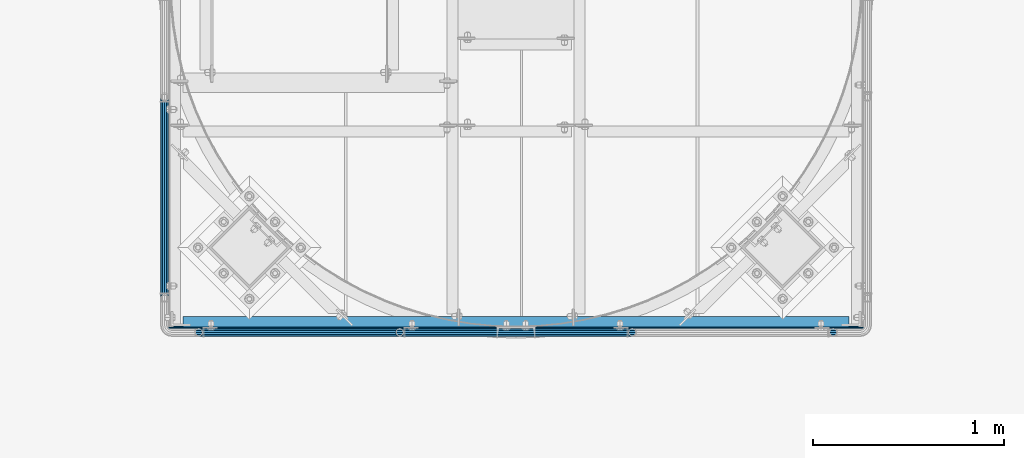
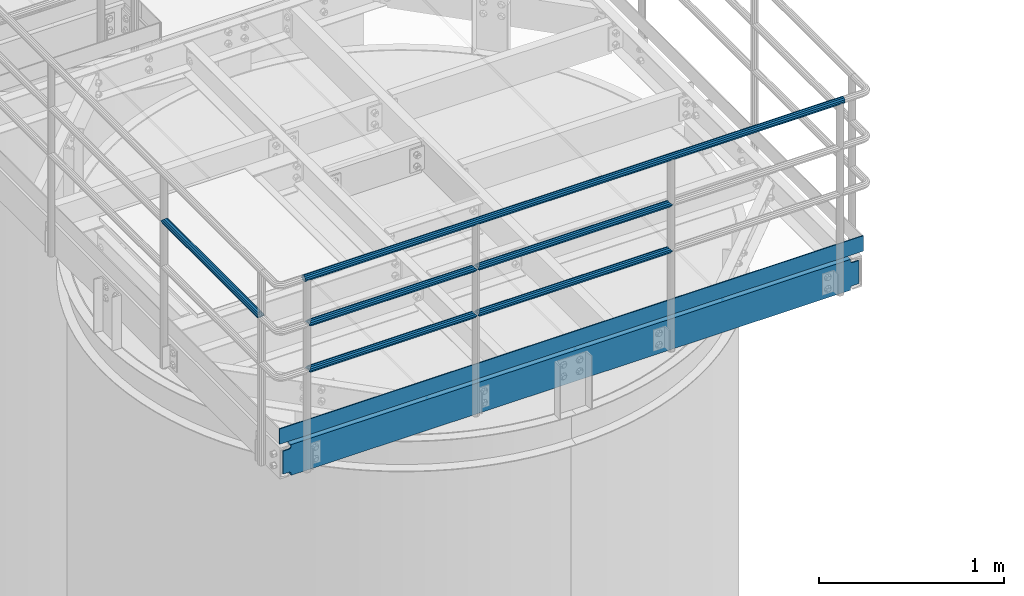
# One storey, part 914 of 1876: 8 beams, 3 elements without a shape of their own.
"""IFC2X3 building model written with IfcOpenShell, lengths in millimetres."""

from ifc_helpers import new_model, si_unit, frame, origin_with_axes, place, context, subcontext, project, spatial, faceted_brep, material, type_object, element, aggregate, save


model = new_model("IFC2X3")

# Units and contexts
model_context = context("Model", 3, precision=1e-05, world=origin_with_axes())
body_context = subcontext(model_context, "Body", "Model", "MODEL_VIEW")
ifc_project = project(units=[si_unit("LENGTHUNIT", "METRE", prefix="MILLI"), si_unit("AREAUNIT", "SQUARE_METRE"), si_unit("VOLUMEUNIT", "CUBIC_METRE"), si_unit("MASSUNIT", "GRAM", prefix="KILO"), si_unit("TIMEUNIT", "SECOND"), si_unit("PLANEANGLEUNIT", "RADIAN"), si_unit("SOLIDANGLEUNIT", "STERADIAN"), si_unit("THERMODYNAMICTEMPERATUREUNIT", "DEGREE_CELSIUS"), si_unit("LUMINOUSINTENSITYUNIT", "LUMEN")], contexts=[model_context])

# Site, building, storey
site_placement = place(None, origin_with_axes())
site = spatial("IfcSite", under=ifc_project, at=site_placement, CompositionType="ELEMENT")
building_placement = place(site_placement, origin_with_axes())
building = spatial("IfcBuilding", under=site, at=building_placement, Name="Undefined", CompositionType="ELEMENT")
storey_placement = place(building_placement, origin_with_axes())
storey = spatial("IfcBuildingStorey", under=building, at=storey_placement, Name="Undefined", CompositionType="ELEMENT", Elevation=0.0)

# Assembly, beams
assembly_1_placement = place(storey_placement, origin_with_axes())
assembly_1 = element("IfcElementAssembly", 1, at=assembly_1_placement, inside=storey, Name="HANDRAIL", AssemblyPlace="NOTDEFINED", PredefinedType="RIGID_FRAME")
ifc_material_1 = material()
beam_type_1 = type_object("IfcBeamType", Name="PIPE1-1/4STD", PredefinedType="NOTDEFINED")
beam_1_placement = place(assembly_1_placement, frame((4572.00143150122, -15432.4964042969, 8480.425), z_axis=(0.0, 0.0, 1.0), x_axis=(1.0, 0.0, 0.0)))
beam_1 = element("IfcBeam", 2, at=beam_1_placement, type_object=beam_type_1, material=ifc_material_1, Name="RAIL", ObjectType="PIPE1-1/4STD", context=body_context, shape_type="Brep", body=[
    faceted_brep([(1200.94245243742, -10.5409999999993, 18.2575475625836), (1200.94245243742, -10.5409999999993, 13.3999612267253), (1200.46603877327, -8.76300000000083, 15.1779612267255), (1198.118, 0.0, 17.5259999999998), (1198.118, 0.0, 21.0820000000003), (1200.46603877327, 8.76300000000083, 15.1779612267255), (1200.94245243742, 10.5409999999993, 13.3999612267253), (1200.94245243742, 10.5409999999993, 18.2575475625836), (1219.2, 21.0820000000003, 0.0), (1208.659, 18.2575475625836, 10.5409999999993), (1208.659, 18.2575475625836, -10.5409999999993), (1205.57941366414, 15.1779612267255, 8.76300000000083), (1207.92745243742, 17.5259999999998, 0.0), (1205.57941366414, 15.1779612267255, -8.76300000000083), (1200.94245243742, 10.5409999999993, -13.3999612267253), (1200.94245243742, 10.5409999999993, -18.2575475625836), (1200.46603877327, 8.76300000000083, -15.1779612267255), (1198.118, 0.0, -17.5259999999998), (1198.118, 0.0, -21.0820000000003), (1200.94245243742, -10.5409999999993, -13.3999612267253), (1200.94245243742, -10.5409999999993, -18.2575475625836), (1200.46603877327, -8.76300000000083, -15.1779612267255), (1219.2, -21.0820000000003, 0.0), (1208.659, -18.2575475625836, -10.5409999999993), (1208.659, -18.2575475625836, 10.5409999999993), (1205.57941366414, -15.1779612267255, -8.76300000000083), (1207.92745243742, -17.5259999999998, 0.0), (1205.57941366414, -15.1779612267255, 8.76300000000083), (10.5409999957128, -18.2575475672238, -10.5409999999993), (18.2575475625817, -10.5410000000011, -18.2575475625836), (9.09494701772928e-13, 21.0820000000003, 0.0), (10.5409999957128, 18.2575475579433, -10.5409999999993), (10.5409999999983, 18.2575475625836, 10.5410000000011), (18.2575475625817, 10.5409999999993, 18.2575475625836), (21.0819999999985, 1.81898940354586e-12, 21.0820000000003), (18.2575475625817, 10.5409999999993, -18.2575475625836), (21.0819999999985, 0.0, -21.0819999999985), (21.0819999999985, 0.0, -17.5259999999998), (18.2575475625817, -10.5409999999974, -13.3999612267271), (18.7339612267233, -8.76300000000083, -15.1779612267255), (18.7339612267251, 8.76299999999901, -15.1779612267255), (18.2575475625817, 10.5410000000011, -13.3999612267235), (13.6205863358573, 15.1779612267255, -8.76299999999901), (11.2725475625839, 17.5259999999998, 0.0), (13.6205863358573, 15.1779612267255, 8.76300000000083), (18.2575475625817, 10.5410000000011, 13.3999612267253), (18.7339612267251, 8.76299999999901, 15.1779612267273), (21.0819999999985, 1.81898940354586e-12, 17.5259999999998), (18.7339612267233, -8.76300000000083, 15.1779612267273), (18.2575475625817, -10.5409999999974, 13.3999612267289), (18.2575475625817, -10.5410000000011, 18.2575475625836), (10.5409999999983, -18.2575475625836, 10.5410000000011), (9.09494701772928e-13, -21.0820000000003, 0.0), (13.6205863358537, -15.1779612267255, 8.76300000000083), (11.2725475625793, -17.5259999999998, 0.0), (13.6205863358537, -15.1779612267255, -8.76299999999901)], [[[0, 1, 2, 3, 4]], [[4, 3, 5, 6, 7]], [[8, 9, 10]], [[7, 6, 11, 12, 13, 14, 15, 10, 9]], [[16, 17, 18, 15, 14]], [[19, 20, 18, 17, 21]], [[22, 23, 24]], [[24, 23, 20, 19, 25, 26, 27, 1, 0]], [[28, 29, 20, 23]], [[30, 31, 32]], [[33, 34, 4, 7]], [[32, 33, 7, 9]], [[30, 32, 9, 8]], [[31, 30, 8, 10]], [[35, 31, 10, 15]], [[36, 35, 15, 18]], [[29, 36, 18, 20]], [[37, 36, 29, 38, 39]], [[40, 41, 35, 36, 37]], [[32, 31, 35, 41, 42, 43, 44, 45, 33]], [[33, 45, 46, 47, 34]], [[34, 47, 48, 49, 50]], [[34, 50, 0, 4]], [[50, 51, 24, 0]], [[51, 52, 22, 24]], [[52, 28, 23, 22]], [[51, 28, 52]], [[50, 49, 53, 54, 55, 38, 29, 28, 51]], [[55, 54, 26, 25]], [[21, 39, 38, 55, 25, 19]], [[37, 39, 21, 17]], [[40, 37, 17, 16]], [[42, 41, 40, 16, 14, 13]], [[43, 42, 13, 12]], [[44, 43, 12, 11]], [[5, 46, 45, 44, 11, 6]], [[47, 46, 5, 3]], [[48, 47, 3, 2]], [[53, 49, 48, 2, 1, 27]], [[54, 53, 27, 26]]]),
])
beam_2_placement = place(assembly_1_placement, frame((3517.90143150122, -15432.4964042969, 8480.425), z_axis=(0.0, 0.0, 1.0), x_axis=(1.0, 0.0, 0.0)))
beam_2 = element("IfcBeam", 3, at=beam_2_placement, type_object=beam_type_1, material=ifc_material_1, Name="RAIL", ObjectType="PIPE1-1/4STD", context=body_context, shape_type="Brep", body=[
    faceted_brep([(1035.84245243742, -10.5409999999993, 18.2575475625836), (1035.84245243742, -10.5409999999993, 13.3999612267253), (1035.36603877327, -8.76300000000083, 15.1779612267255), (1033.018, 0.0, 17.5259999999998), (1033.018, 0.0, 21.0820000000003), (1035.36603877327, 8.76300000000083, 15.1779612267255), (1035.84245243742, 10.5409999999993, 13.3999612267253), (1035.84245243742, 10.5409999999993, 18.2575475625836), (1054.1, 21.0820000000003, 0.0), (1043.559, 18.2575475625836, 10.5409999999993), (1043.559, 18.2575475625836, -10.5409999999993), (1040.47941366414, 15.1779612267255, 8.76300000000083), (1042.82745243742, 17.5259999999998, 0.0), (1040.47941366414, 15.1779612267255, -8.76300000000083), (1035.84245243742, 10.5409999999993, -13.3999612267253), (1035.84245243742, 10.5409999999993, -18.2575475625836), (1035.36603877327, 8.76300000000083, -15.1779612267255), (1033.018, 0.0, -17.5259999999998), (1033.018, 0.0, -21.0820000000003), (1035.84245243742, -10.5409999999993, -13.3999612267253), (1035.84245243742, -10.5409999999993, -18.2575475625836), (1035.36603877327, -8.76300000000083, -15.1779612267255), (1054.1, -21.0820000000003, 0.0), (1043.559, -18.2575475625836, -10.5409999999993), (1043.559, -18.2575475625836, 10.5409999999993), (1040.47941366414, -15.1779612267255, -8.76300000000083), (1042.82745243742, -17.5259999999998, 0.0), (1040.47941366414, -15.1779612267255, 8.76300000000083), (10.5409999957128, -18.2575475672238, -10.5409999999993), (18.2575475625817, -10.5410000000011, -18.2575475625836), (9.09494701772928e-13, 21.0820000000003, 0.0), (10.5409999957128, 18.2575475579433, -10.5409999999993), (10.5409999999983, 18.2575475625836, 10.5410000000011), (18.2575475625817, 10.5409999999993, 18.2575475625836), (21.0819999999985, 1.81898940354586e-12, 21.0820000000003), (18.2575475625817, 10.5409999999993, -18.2575475625836), (21.0819999999985, 0.0, -21.0819999999985), (21.0819999999985, 0.0, -17.5259999999998), (18.2575475625817, -10.5409999999974, -13.3999612267271), (18.7339612267233, -8.76300000000083, -15.1779612267255), (18.7339612267251, 8.76299999999901, -15.1779612267255), (18.2575475625817, 10.5410000000011, -13.3999612267235), (13.6205863358573, 15.1779612267255, -8.76299999999901), (11.2725475625839, 17.5259999999998, 0.0), (13.6205863358573, 15.1779612267255, 8.76300000000083), (18.2575475625817, 10.5410000000011, 13.3999612267253), (18.7339612267251, 8.76299999999901, 15.1779612267273), (21.0819999999985, 1.81898940354586e-12, 17.5259999999998), (18.7339612267233, -8.76300000000083, 15.1779612267273), (18.2575475625817, -10.5409999999974, 13.3999612267289), (18.2575475625817, -10.5410000000011, 18.2575475625836), (10.5409999999983, -18.2575475625836, 10.5410000000011), (9.09494701772928e-13, -21.0820000000003, 0.0), (13.6205863358537, -15.1779612267255, 8.76300000000083), (11.2725475625793, -17.5259999999998, 0.0), (13.6205863358537, -15.1779612267255, -8.76299999999901)], [[[0, 1, 2, 3, 4]], [[4, 3, 5, 6, 7]], [[8, 9, 10]], [[7, 6, 11, 12, 13, 14, 15, 10, 9]], [[16, 17, 18, 15, 14]], [[19, 20, 18, 17, 21]], [[22, 23, 24]], [[24, 23, 20, 19, 25, 26, 27, 1, 0]], [[28, 29, 20, 23]], [[30, 31, 32]], [[33, 34, 4, 7]], [[32, 33, 7, 9]], [[30, 32, 9, 8]], [[31, 30, 8, 10]], [[35, 31, 10, 15]], [[36, 35, 15, 18]], [[29, 36, 18, 20]], [[37, 36, 29, 38, 39]], [[40, 41, 35, 36, 37]], [[32, 31, 35, 41, 42, 43, 44, 45, 33]], [[33, 45, 46, 47, 34]], [[34, 47, 48, 49, 50]], [[34, 50, 0, 4]], [[50, 51, 24, 0]], [[51, 52, 22, 24]], [[52, 28, 23, 22]], [[51, 28, 52]], [[50, 49, 53, 54, 55, 38, 29, 28, 51]], [[55, 54, 26, 25]], [[21, 39, 38, 55, 25, 19]], [[37, 39, 21, 17]], [[40, 37, 17, 16]], [[42, 41, 40, 16, 14, 13]], [[43, 42, 13, 12]], [[44, 43, 12, 11]], [[5, 46, 45, 44, 11, 6]], [[47, 46, 5, 3]], [[48, 47, 3, 2]], [[53, 49, 48, 2, 1, 27]], [[54, 53, 27, 26]]]),
])

# Assembly, beam
assembly_2_placement = place(storey_placement, origin_with_axes())
assembly_2 = element("IfcElementAssembly", 4, at=assembly_2_placement, inside=storey, Name="HANDRAIL", AssemblyPlace="NOTDEFINED", PredefinedType="RIGID_FRAME")
beam_3_placement = place(assembly_2_placement, frame((3338.06943150122, -14198.5644042969, 8785.225), z_axis=(0.0, 0.0, -1.0), x_axis=(0.0, -1.0, 0.0)))
beam_3 = element("IfcBeam", 5, at=beam_3_placement, type_object=beam_type_1, material=ifc_material_1, Name="RAIL", ObjectType="PIPE1-1/4STD", context=body_context, shape_type="Brep", body=[
    faceted_brep([(9.09494701772928e-13, 21.0820000000003, 0.0), (10.5409999957128, 18.2575475579433, -10.5409999999993), (10.5409999999983, 18.2575475625836, 10.5410000000011), (10.5409999999983, -18.2575475625836, 10.5410000000011), (10.5409999957128, -18.2575475672238, -10.5409999999993), (9.09494701772928e-13, -21.0820000000003, 0.0), (18.2575475625817, -10.5410000000011, 18.2575475625836), (18.2575475625817, -10.5409999999974, 13.3999612267289), (13.6205863358537, -15.1779612267255, 8.76300000000083), (11.2725475625793, -17.5259999999998, 0.0), (13.6205863358537, -15.1779612267255, -8.76299999999901), (18.2575475625817, -10.5409999999974, -13.3999612267271), (18.2575475625817, -10.5410000000011, -18.2575475625836), (21.0819999999985, 0.0, -17.5259999999998), (21.0819999999985, 0.0, -21.0819999999985), (18.7339612267233, -8.76300000000083, -15.1779612267255), (18.7339612267251, 8.76299999999901, -15.1779612267255), (18.2575475625817, 10.5410000000011, -13.3999612267235), (18.2575475625817, 10.5409999999993, -18.2575475625836), (13.6205863358573, 15.1779612267255, -8.76299999999901), (11.2725475625839, 17.5259999999998, 0.0), (13.6205863358573, 15.1779612267255, 8.76300000000083), (18.2575475625817, 10.5410000000011, 13.3999612267253), (18.2575475625817, 10.5409999999993, 18.2575475625836), (18.7339612267251, 8.76299999999901, 15.1779612267273), (21.0819999999985, 1.81898940354586e-12, 17.5259999999998), (21.0819999999985, 1.81898940354586e-12, 21.0820000000003), (18.7339612267233, -8.76300000000083, 15.1779612267273), (1054.1, 21.0820000000003, 0.0), (1043.559, 18.2575475625836, -10.5409999999993), (1035.84245243742, 10.5409999999993, -18.2575475625836), (1054.1, -21.0820000000003, 0.0), (1043.559, -18.2575475625836, -10.5409999999993), (1043.559, -18.2575475625836, 10.5409999999993), (1035.84245243742, -10.5409999999993, 18.2575475625836), (1035.84245243742, -10.5409999999993, -18.2575475625836), (1033.018, 0.0, -21.0820000000003), (1035.36603877327, 8.76300000000083, -15.1779612267255), (1033.018, 0.0, -17.5259999999998), (1035.84245243742, 10.5409999999993, -13.3999612267253), (1035.84245243742, -10.5409999999993, -13.3999612267253), (1035.36603877327, -8.76300000000083, -15.1779612267255), (1040.47941366414, -15.1779612267255, -8.76300000000083), (1042.82745243742, -17.5259999999998, 0.0), (1040.47941366414, -15.1779612267255, 8.76300000000083), (1035.84245243742, -10.5409999999993, 13.3999612267253), (1035.36603877327, -8.76300000000083, 15.1779612267255), (1033.018, 0.0, 17.5259999999998), (1033.018, 0.0, 21.0820000000003), (1035.84245243742, 10.5409999999993, 18.2575475625836), (1043.559, 18.2575475625836, 10.5409999999993), (1035.84245243742, 10.5409999999993, 13.3999612267253), (1040.47941366414, 15.1779612267255, 8.76300000000083), (1042.82745243742, 17.5259999999998, 0.0), (1040.47941366414, 15.1779612267255, -8.76300000000083), (1035.36603877327, 8.76300000000083, 15.1779612267255)], [[[0, 1, 2]], [[3, 4, 5]], [[6, 7, 8, 9, 10, 11, 12, 4, 3]], [[13, 14, 12, 11, 15]], [[16, 17, 18, 14, 13]], [[2, 1, 18, 17, 19, 20, 21, 22, 23]], [[23, 22, 24, 25, 26]], [[26, 25, 27, 7, 6]], [[1, 0, 28, 29]], [[18, 1, 29, 30]], [[31, 32, 33]], [[6, 3, 33, 34]], [[3, 5, 31, 33]], [[5, 4, 32, 31]], [[4, 12, 35, 32]], [[12, 14, 36, 35]], [[14, 18, 30, 36]], [[37, 38, 36, 30, 39]], [[40, 35, 36, 38, 41]], [[33, 32, 35, 40, 42, 43, 44, 45, 34]], [[34, 45, 46, 47, 48]], [[26, 6, 34, 48]], [[2, 23, 49, 50]], [[23, 26, 48, 49]], [[0, 2, 50, 28]], [[28, 50, 29]], [[49, 51, 52, 53, 54, 39, 30, 29, 50]], [[48, 47, 55, 51, 49]], [[25, 24, 55, 47]], [[55, 24, 22, 21, 52, 51]], [[21, 20, 53, 52]], [[20, 19, 54, 53]], [[19, 17, 16, 37, 39, 54]], [[16, 13, 38, 37]], [[13, 15, 41, 38]], [[41, 15, 11, 10, 42, 40]], [[10, 9, 43, 42]], [[9, 8, 44, 43]], [[8, 7, 27, 46, 45, 44]], [[27, 25, 47, 46]]]),
])
aggregate(assembly_2, [beam_3])

# Beam
beam_4_placement = place(assembly_1_placement, frame((5791.20143150122, -15432.4964042969, 8785.225), z_axis=(0.0, 0.0, -1.0), x_axis=(-1.0, 0.0, 0.0)))
beam_4 = element("IfcBeam", 6, at=beam_4_placement, type_object=beam_type_1, material=ifc_material_1, Name="RAIL", ObjectType="PIPE1-1/4STD", context=body_context, shape_type="Brep", body=[
    faceted_brep([(9.09494701772928e-13, 21.0820000000003, 0.0), (10.5409999957128, 18.2575475579433, -10.5409999999993), (10.5409999999983, 18.2575475625836, 10.5410000000011), (10.5409999999983, -18.2575475625836, 10.5410000000011), (10.5409999957128, -18.2575475672238, -10.5409999999993), (9.09494701772928e-13, -21.0820000000003, 0.0), (18.2575475625817, -10.5410000000011, 18.2575475625836), (18.2575475625817, -10.5409999999974, 13.3999612267289), (13.6205863358537, -15.1779612267255, 8.76300000000083), (11.2725475625793, -17.5259999999998, 0.0), (13.6205863358537, -15.1779612267255, -8.76299999999901), (18.2575475625817, -10.5409999999974, -13.3999612267271), (18.2575475625817, -10.5410000000011, -18.2575475625836), (21.0819999999985, 0.0, -17.5259999999998), (21.0819999999985, 0.0, -21.0819999999985), (18.7339612267233, -8.76300000000083, -15.1779612267255), (18.7339612267251, 8.76299999999901, -15.1779612267255), (18.2575475625817, 10.5410000000011, -13.3999612267235), (18.2575475625817, 10.5409999999993, -18.2575475625836), (13.6205863358573, 15.1779612267255, -8.76299999999901), (11.2725475625839, 17.5259999999998, 0.0), (13.6205863358573, 15.1779612267255, 8.76300000000083), (18.2575475625817, 10.5410000000011, 13.3999612267253), (18.2575475625817, 10.5409999999993, 18.2575475625836), (18.7339612267251, 8.76299999999901, 15.1779612267273), (21.0819999999985, 1.81898940354586e-12, 17.5259999999998), (21.0819999999985, 1.81898940354586e-12, 21.0820000000003), (18.7339612267233, -8.76300000000083, 15.1779612267273), (1219.2, 21.0820000000003, 0.0), (1208.659, 18.2575475625836, -10.5409999999993), (1200.94245243742, 10.5409999999993, -18.2575475625836), (1219.2, -21.0820000000003, 0.0), (1208.659, -18.2575475625836, -10.5409999999993), (1208.659, -18.2575475625836, 10.5409999999993), (1200.94245243742, -10.5409999999993, 18.2575475625836), (1200.94245243742, -10.5409999999993, -18.2575475625836), (1198.118, 0.0, -21.0820000000003), (1200.46603877327, 8.76300000000083, -15.1779612267255), (1198.118, 0.0, -17.5259999999998), (1200.94245243742, 10.5409999999993, -13.3999612267253), (1200.94245243742, -10.5409999999993, -13.3999612267253), (1200.46603877327, -8.76300000000083, -15.1779612267255), (1205.57941366414, -15.1779612267255, -8.76300000000083), (1207.92745243742, -17.5259999999998, 0.0), (1205.57941366414, -15.1779612267255, 8.76300000000083), (1200.94245243742, -10.5409999999993, 13.3999612267253), (1200.46603877327, -8.76300000000083, 15.1779612267255), (1198.118, 0.0, 17.5259999999998), (1198.118, 0.0, 21.0820000000003), (1200.94245243742, 10.5409999999993, 18.2575475625836), (1208.659, 18.2575475625836, 10.5409999999993), (1200.94245243742, 10.5409999999993, 13.3999612267253), (1205.57941366414, 15.1779612267255, 8.76300000000083), (1207.92745243742, 17.5259999999998, 0.0), (1205.57941366414, 15.1779612267255, -8.76300000000083), (1200.46603877327, 8.76300000000083, 15.1779612267255)], [[[0, 1, 2]], [[3, 4, 5]], [[6, 7, 8, 9, 10, 11, 12, 4, 3]], [[13, 14, 12, 11, 15]], [[16, 17, 18, 14, 13]], [[2, 1, 18, 17, 19, 20, 21, 22, 23]], [[23, 22, 24, 25, 26]], [[26, 25, 27, 7, 6]], [[1, 0, 28, 29]], [[18, 1, 29, 30]], [[31, 32, 33]], [[6, 3, 33, 34]], [[3, 5, 31, 33]], [[5, 4, 32, 31]], [[4, 12, 35, 32]], [[12, 14, 36, 35]], [[14, 18, 30, 36]], [[37, 38, 36, 30, 39]], [[40, 35, 36, 38, 41]], [[33, 32, 35, 40, 42, 43, 44, 45, 34]], [[34, 45, 46, 47, 48]], [[26, 6, 34, 48]], [[2, 23, 49, 50]], [[23, 26, 48, 49]], [[0, 2, 50, 28]], [[28, 50, 29]], [[49, 51, 52, 53, 54, 39, 30, 29, 50]], [[48, 47, 55, 51, 49]], [[25, 24, 55, 47]], [[55, 24, 22, 21, 52, 51]], [[21, 20, 53, 52]], [[20, 19, 54, 53]], [[19, 17, 16, 37, 39, 54]], [[16, 13, 38, 37]], [[13, 15, 41, 38]], [[41, 15, 11, 10, 42, 40]], [[10, 9, 43, 42]], [[9, 8, 44, 43]], [[8, 7, 27, 46, 45, 44]], [[27, 25, 47, 46]]]),
])

beam_5_placement = place(assembly_1_placement, frame((6866.38343150122, -15432.4964042969, 9090.025), z_axis=(0.0, 0.0, -1.0), x_axis=(-1.0, 0.0, 0.0)))
beam_5 = element("IfcBeam", 7, at=beam_5_placement, type_object=beam_type_1, material=ifc_material_1, Name="HANDRAIL", ObjectType="PIPE1-1/4STD", context=body_context, shape_type="Brep", body=[
    faceted_brep([(0.0, -17.5259999999998, 0.0), (0.0, -15.1779612267264, 8.76300000000083), (3369.564, -15.177961226726, 8.76300000000083), (3369.564, -17.5259999999998, 0.0), (0.0, -8.76299999999992, 15.1779612267255), (3369.564, -8.76299999999992, 15.1779612267255), (0.0, 0.0, 17.5259999999998), (3369.564, 0.0, 17.5259999999998), (0.0, 8.76299999999992, 15.1779612267255), (3369.564, 8.76299999999992, 15.1779612267255), (0.0, 15.1779612267264, 8.76300000000083), (3369.564, 15.177961226726, 8.76300000000083), (0.0, 17.5259999999998, 0.0), (3369.564, 17.5259999999998, 0.0), (0.0, 15.1779612267264, -8.76300000000083), (3369.564, 15.177961226726, -8.76300000000083), (0.0, 8.76299999999992, -15.1779612267255), (3369.564, 8.76299999999992, -15.1779612267255), (0.0, 0.0, -17.5259999999998), (3369.564, 0.0, -17.5259999999998), (0.0, -8.76299999999992, -15.1779612267255), (3369.564, -8.76299999999992, -15.1779612267255), (0.0, -15.1779612267264, -8.76300000000083), (3369.564, -15.177961226726, -8.76300000000083), (9.09494701772928e-13, -21.0820000000003, 0.0), (0.0, -18.2575475625836, -10.5409999999993), (3369.564, -18.2575475625836, -10.5409999999993), (3369.564, -21.0819999999999, 0.0), (0.0, -10.5410000000002, -18.2575475625836), (3369.564, -10.5410000000002, -18.2575475625836), (-4.28826751885936e-09, 0.0, -21.0820000000003), (3369.564, 0.0, -21.0820000000003), (0.0, 10.5410000000002, -18.2575475625836), (3369.564, 10.5410000000002, -18.2575475625836), (0.0, 18.2575475625836, -10.5409999999993), (3369.564, 18.2575475625836, -10.5409999999993), (9.09494701772928e-13, 21.0820000000003, 0.0), (3369.564, 21.0819999999999, 0.0), (0.0, 18.2575475625836, 10.5409999999993), (3369.564, 18.2575475625836, 10.5409999999993), (0.0, 10.5410000000002, 18.2575475625836), (3369.564, 10.5410000000002, 18.2575475625836), (0.0, 0.0, 21.0820000000003), (3369.564, 0.0, 21.0820000000003), (0.0, -10.5410000000002, 18.2575475625836), (3369.564, -10.5410000000002, 18.2575475625836), (0.0, -18.2575475625836, 10.5409999999993), (3369.564, -18.2575475625836, 10.5409999999993)], [[[0, 1, 2, 3]], [[1, 4, 5, 2]], [[4, 6, 7, 5]], [[6, 8, 9, 7]], [[8, 10, 11, 9]], [[10, 12, 13, 11]], [[12, 14, 15, 13]], [[14, 16, 17, 15]], [[16, 18, 19, 17]], [[18, 20, 21, 19]], [[20, 22, 23, 21]], [[22, 0, 3, 23]], [[24, 25, 26, 27]], [[25, 28, 29, 26]], [[28, 30, 31, 29]], [[30, 32, 33, 31]], [[32, 34, 35, 33]], [[34, 36, 37, 35]], [[36, 38, 39, 37]], [[38, 40, 41, 39]], [[40, 42, 43, 41]], [[42, 44, 45, 43]], [[44, 46, 47, 45]], [[46, 24, 27, 47]], [[29, 31, 33, 35, 37, 39, 41, 43, 45, 47, 27, 26], [5, 7, 9, 11, 13, 15, 17, 19, 21, 23, 3, 2]], [[46, 44, 42, 40, 38, 36, 34, 32, 30, 28, 25, 24], [22, 20, 18, 16, 14, 12, 10, 8, 6, 4, 1, 0]]]),
])

beam_6_placement = place(assembly_1_placement, frame((4572.00143150122, -15432.4964042969, 8785.225), z_axis=(0.0, 0.0, -1.0), x_axis=(-1.0, 0.0, 0.0)))
beam_6 = element("IfcBeam", 8, at=beam_6_placement, type_object=beam_type_1, material=ifc_material_1, Name="RAIL", ObjectType="PIPE1-1/4STD", context=body_context, shape_type="Brep", body=[
    faceted_brep([(9.09494701772928e-13, 21.0820000000003, 0.0), (10.5409999957128, 18.2575475579433, -10.5409999999993), (10.5409999999983, 18.2575475625836, 10.5410000000011), (10.5409999999983, -18.2575475625836, 10.5410000000011), (10.5409999957128, -18.2575475672238, -10.5409999999993), (9.09494701772928e-13, -21.0820000000003, 0.0), (18.2575475625817, -10.5410000000011, 18.2575475625836), (18.2575475625817, -10.5409999999974, 13.3999612267289), (13.6205863358537, -15.1779612267255, 8.76300000000083), (11.2725475625793, -17.5259999999998, 0.0), (13.6205863358537, -15.1779612267255, -8.76299999999901), (18.2575475625817, -10.5409999999974, -13.3999612267271), (18.2575475625817, -10.5410000000011, -18.2575475625836), (21.0819999999985, 0.0, -17.5259999999998), (21.0819999999985, 0.0, -21.0819999999985), (18.7339612267233, -8.76300000000083, -15.1779612267255), (18.7339612267251, 8.76299999999901, -15.1779612267255), (18.2575475625817, 10.5410000000011, -13.3999612267235), (18.2575475625817, 10.5409999999993, -18.2575475625836), (13.6205863358573, 15.1779612267255, -8.76299999999901), (11.2725475625839, 17.5259999999998, 0.0), (13.6205863358573, 15.1779612267255, 8.76300000000083), (18.2575475625817, 10.5410000000011, 13.3999612267253), (18.2575475625817, 10.5409999999993, 18.2575475625836), (18.7339612267251, 8.76299999999901, 15.1779612267273), (21.0819999999985, 1.81898940354586e-12, 17.5259999999998), (21.0819999999985, 1.81898940354586e-12, 21.0820000000003), (18.7339612267233, -8.76300000000083, 15.1779612267273), (1054.1, 21.0820000000003, 0.0), (1043.559, 18.2575475625836, -10.5409999999993), (1035.84245243742, 10.5409999999993, -18.2575475625836), (1054.1, -21.0820000000003, 0.0), (1043.559, -18.2575475625836, -10.5409999999993), (1043.559, -18.2575475625836, 10.5409999999993), (1035.84245243742, -10.5409999999993, 18.2575475625836), (1035.84245243742, -10.5409999999993, -18.2575475625836), (1033.018, 0.0, -21.0820000000003), (1035.36603877327, 8.76300000000083, -15.1779612267255), (1033.018, 0.0, -17.5259999999998), (1035.84245243742, 10.5409999999993, -13.3999612267253), (1035.84245243742, -10.5409999999993, -13.3999612267253), (1035.36603877327, -8.76300000000083, -15.1779612267255), (1040.47941366414, -15.1779612267255, -8.76300000000083), (1042.82745243742, -17.5259999999998, 0.0), (1040.47941366414, -15.1779612267255, 8.76300000000083), (1035.84245243742, -10.5409999999993, 13.3999612267253), (1035.36603877327, -8.76300000000083, 15.1779612267255), (1033.018, 0.0, 17.5259999999998), (1033.018, 0.0, 21.0820000000003), (1035.84245243742, 10.5409999999993, 18.2575475625836), (1043.559, 18.2575475625836, 10.5409999999993), (1035.84245243742, 10.5409999999993, 13.3999612267253), (1040.47941366414, 15.1779612267255, 8.76300000000083), (1042.82745243742, 17.5259999999998, 0.0), (1040.47941366414, 15.1779612267255, -8.76300000000083), (1035.36603877327, 8.76300000000083, 15.1779612267255)], [[[0, 1, 2]], [[3, 4, 5]], [[6, 7, 8, 9, 10, 11, 12, 4, 3]], [[13, 14, 12, 11, 15]], [[16, 17, 18, 14, 13]], [[2, 1, 18, 17, 19, 20, 21, 22, 23]], [[23, 22, 24, 25, 26]], [[26, 25, 27, 7, 6]], [[1, 0, 28, 29]], [[18, 1, 29, 30]], [[31, 32, 33]], [[6, 3, 33, 34]], [[3, 5, 31, 33]], [[5, 4, 32, 31]], [[4, 12, 35, 32]], [[12, 14, 36, 35]], [[14, 18, 30, 36]], [[37, 38, 36, 30, 39]], [[40, 35, 36, 38, 41]], [[33, 32, 35, 40, 42, 43, 44, 45, 34]], [[34, 45, 46, 47, 48]], [[26, 6, 34, 48]], [[2, 23, 49, 50]], [[23, 26, 48, 49]], [[0, 2, 50, 28]], [[28, 50, 29]], [[49, 51, 52, 53, 54, 39, 30, 29, 50]], [[48, 47, 55, 51, 49]], [[25, 24, 55, 47]], [[55, 24, 22, 21, 52, 51]], [[21, 20, 53, 52]], [[20, 19, 54, 53]], [[19, 17, 16, 37, 39, 54]], [[16, 13, 38, 37]], [[13, 15, 41, 38]], [[41, 15, 11, 10, 42, 40]], [[10, 9, 43, 42]], [[9, 8, 44, 43]], [[8, 7, 27, 46, 45, 44]], [[27, 25, 47, 46]]]),
])

ifc_material_2 = material(Name="STEEL/A36")
beam_type_2 = type_object("IfcBeamType", PredefinedType="NOTDEFINED")
beam_7_placement = place(assembly_1_placement, frame((3359.15143150122, -15408.2394042969, 8080.375), z_axis=(0.0, 0.0, 1.0), x_axis=(1.0, 0.0, 0.0)))
beam_7 = element("IfcBeam", 9, at=beam_7_placement, type_object=beam_type_2, material=ifc_material_2, Name="PLATE", context=body_context, shape_type="Brep", body=[
    faceted_brep([(0.0, 3.17500000000018, -50.8000000000002), (0.0, 3.17500000000018, 50.8000000000002), (3644.89713699757, 3.17499999999927, 50.8000000000002), (3644.89713699757, 3.17499999999927, -50.8000000000002), (0.0, -3.17500000000018, 50.8000000000002), (3644.89713699757, -3.17499999999927, 50.8000000000002), (0.0, -3.17500000000018, -50.8000000000002), (3644.89713699757, -3.17499999999927, -50.8000000000002)], [[[0, 1, 2, 3]], [[1, 4, 5, 2]], [[4, 6, 7, 5]], [[6, 0, 3, 7]], [[5, 7, 3, 2]], [[6, 4, 1, 0]]]),
])

aggregate(assembly_1, [beam_1, beam_2, beam_7, beam_4, beam_5, beam_6])

# Assembly, beam
assembly_3_placement = place(storey_placement, origin_with_axes())
assembly_3 = element("IfcElementAssembly", 10, at=assembly_3_placement, inside=storey, Name="BEAM", AssemblyPlace="NOTDEFINED", PredefinedType="RIGID_FRAME")
beam_type_3 = type_object("IfcBeamType", Name="C8X11.5", PredefinedType="NOTDEFINED")
beam_8_placement = place(assembly_3_placement, frame((3365.50143150122, -15376.4894042969, 7896.225), z_axis=(0.0, 0.0, -1.0), x_axis=(1.0, 0.0, 0.0)))
beam_8 = element("IfcBeam", 11, at=beam_8_placement, type_object=beam_type_3, material=ifc_material_2, Name="BEAM", ObjectType="C8X11.5", context=body_context, shape_type="Brep", body=[
    faceted_brep([(3562.34713699756, -28.5749999999998, -96.8355949999996), (3562.34713699756, -28.5749999999998, -101.6), (3562.34713699756, 28.5749999999998, -101.6), (3562.34713699756, 28.5749999999998, -88.8999998092659), (3562.34713699756, 19.0576241940826, -88.8999998092659), (3562.45210003221, 22.2250000000004, -88.3723149999996), (3563.31386692015, 28.5749999999998, -84.0399202912204), (3563.31386692015, 22.2250000000004, -84.0399202912204), (3566.06688082063, 28.5749999999998, -79.9197438230667), (3566.06688082063, 22.2250000000004, -79.9197438230667), (3570.18705728878, 28.5749999999998, -77.1667299225883), (3570.18705728878, 22.2250000000004, -77.1667299225883), (3575.04713680683, 28.5749999999998, -76.2000000000007), (3575.04713680683, 22.2250000000004, -76.2000000000007), (3613.14713699757, 22.2250000000004, -76.2000000000007), (3613.14713699757, 28.5749999999998, -76.2000000000007), (69.8500000000013, 28.5750000000007, 101.6), (69.8500000000013, -28.5750000000007, 101.6), (3562.34713699756, -28.5749999999998, 101.6), (3562.34713699756, 28.5749999999998, 101.6), (69.8500000000013, 19.0576241940817, -88.8999998092659), (69.8500000000013, 28.5750000000007, -88.8999998092659), (69.8500000000013, 28.5750000000007, -101.6), (69.8500000000013, -28.5750000000007, -101.6), (69.8500000000013, -28.5750000000007, -96.8355949999996), (69.7450369653598, 22.2250000000004, -88.3723149999996), (68.8832700774137, 22.2250000000004, -84.0399202912204), (68.8832700774137, 28.5750000000007, -84.0399202912204), (66.1302561769353, 22.2250000000004, -79.9197438230667), (66.1302561769353, 28.5750000000007, -79.9197438230667), (62.0100797087816, 22.2250000000004, -77.1667299225883), (62.0100797087816, 28.5750000000007, -77.1667299225883), (57.1500001907361, 22.2250000000004, -76.2000000000007), (57.1500001907361, 28.5750000000007, -76.2000000000007), (19.0499999999993, 22.2250000000004, -76.2000000000007), (19.0499999999993, 28.5750000000007, -76.2000000000007), (19.0499999999993, 22.2250000000004, 76.1999999999989), (19.0499999999993, 28.5750000000007, 76.1999999999989), (57.1500001907361, 22.2250000000004, 76.1999999999989), (57.1500001907361, 28.5750000000007, 76.1999999999989), (62.0100797087816, 22.2250000000004, 77.1667299225865), (62.0100797087816, 28.5750000000007, 77.1667299225865), (66.1302561769353, 22.2250000000004, 79.9197438230649), (66.1302561769353, 28.5750000000007, 79.9197438230649), (68.8832700774137, 22.2250000000004, 84.0399202912186), (68.8832700774137, 28.5750000000007, 84.0399202912186), (69.8500000000013, 19.0576241940926, 88.899999809264), (69.8500000000013, 28.5750000000007, 88.899999809264), (69.7450369653607, 22.2250000000004, 88.3723149999996), (69.8500000000013, -28.5750000000007, 96.8355949999996), (3562.34713699756, -28.5749999999998, 96.8355949999996), (3562.34713699756, 19.0576241940935, 88.899999809264), (3562.34713699756, 28.5749999999998, 88.899999809264), (3562.4521000322, 22.2250000000004, 88.3723149999996), (3563.31386692015, 22.2250000000004, 84.0399202912186), (3563.31386692015, 28.5749999999998, 84.0399202912186), (3566.06688082063, 22.2250000000004, 79.9197438230649), (3566.06688082063, 28.5749999999998, 79.9197438230649), (3570.18705728878, 22.2250000000004, 77.1667299225865), (3570.18705728878, 28.5749999999998, 77.1667299225865), (3575.04713680683, 22.2250000000004, 76.1999999999989), (3575.04713680683, 28.5749999999998, 76.1999999999989), (3613.14713699757, 22.2250000000004, 76.1999999999989), (3613.14713699757, 28.5749999999998, 76.1999999999989)], [[[0, 1, 2, 3, 4]], [[5, 4, 3, 6, 7]], [[7, 6, 8, 9]], [[9, 8, 10, 11]], [[11, 10, 12, 13]], [[14, 13, 12, 15]], [[16, 17, 18, 19]], [[20, 21, 22, 23, 24]], [[25, 26, 27, 21, 20]], [[28, 29, 27, 26]], [[30, 31, 29, 28]], [[32, 33, 31, 30]], [[34, 35, 33, 32]], [[36, 37, 35, 34]], [[38, 39, 37, 36]], [[40, 41, 39, 38]], [[42, 43, 41, 40]], [[44, 45, 43, 42]], [[46, 47, 45, 44, 48]], [[17, 16, 47, 46, 49]], [[17, 49, 50, 18]], [[18, 50, 51, 52, 19]], [[49, 46, 48, 53, 51, 50]], [[54, 55, 52, 51, 53]], [[56, 57, 55, 54]], [[58, 59, 57, 56]], [[60, 61, 59, 58]], [[62, 63, 61, 60]], [[63, 62, 14, 15]], [[10, 8, 6, 3, 2, 22, 21, 27, 29, 31, 33, 35, 37, 39, 41, 43, 45, 47, 16, 19, 52, 55, 57, 59, 61, 63, 15, 12]], [[23, 22, 2, 1]], [[24, 23, 1, 0]], [[25, 20, 24, 0, 4, 5]], [[62, 60, 58, 56, 54, 53, 48, 44, 42, 40, 38, 36, 34, 32, 30, 28, 26, 25, 5, 7, 9, 11, 13, 14]]]),
])
aggregate(assembly_3, [beam_8])

save(model, "model.ifc")
